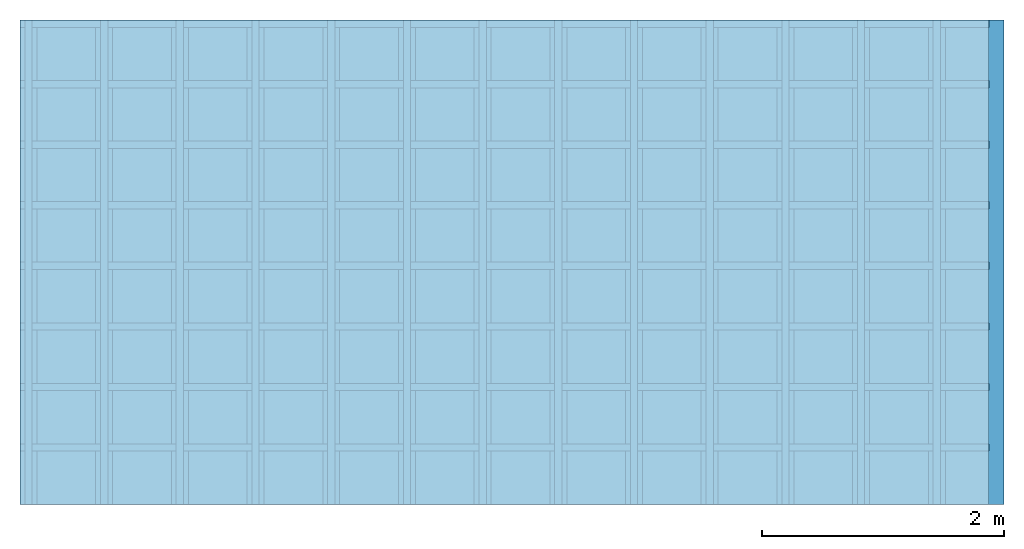
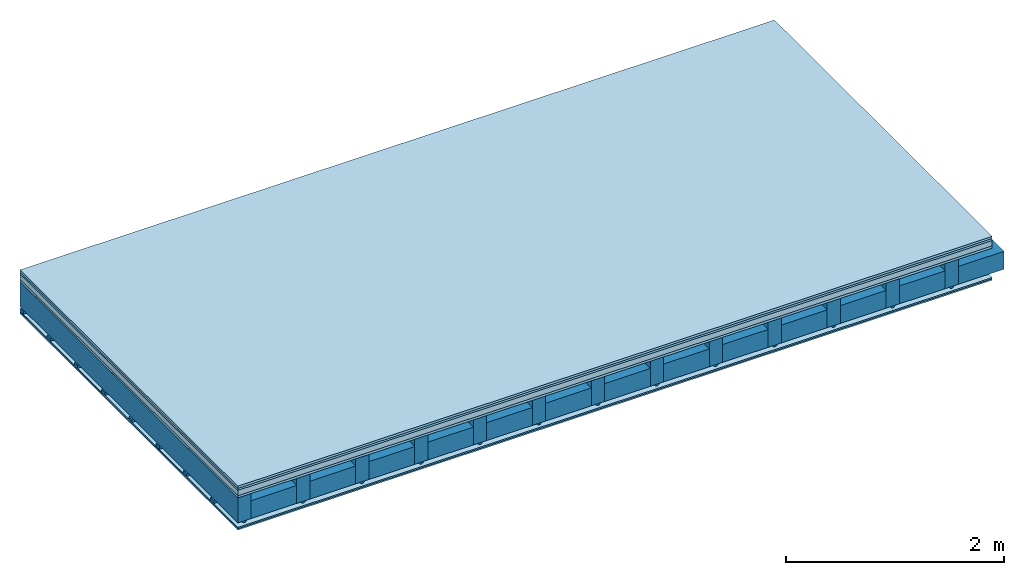
# One storey: 6 plates, 4 members, 1 element without a shape of its own.
"""IFC4 building model written with IfcOpenShell, lengths in metres."""

from ifc_helpers import new_model, si_unit, derived_unit, direction, frame, frame_2d, origin, origin_with_axes, place, context, project, spatial, polyline, rectangle, outline, extrude, material, layer, layer_set, type_object, element, aggregate, save


model = new_model("IFC4")

# Units and contexts
plan_context = context("Plan", 3, precision=1e-05, world=origin(), true_north=direction((0.0, 1.0)))
model_context = context("Model", 3, precision=1e-05, world=origin(), true_north=direction((0.0, 1.0)))
ifc_project = project(units=[si_unit("LENGTHUNIT", "METRE"), derived_unit("SOUNDPRESSUREUNIT", [(si_unit("PRESSUREUNIT", "PASCAL", prefix="MICRO"), 0)]), si_unit("ENERGYUNIT", "JOULE", prefix="MEGA"), si_unit("MASSUNIT", "GRAM", prefix="KILO"), derived_unit("THERMALTRANSMITTANCEUNIT", [(si_unit("POWERUNIT", "WATT"), 1), (si_unit("AREAUNIT", "SQUARE_METRE"), -1), (si_unit("THERMODYNAMICTEMPERATUREUNIT", "KELVIN"), -1)]), derived_unit("AREADENSITYUNIT", [(si_unit("MASSUNIT", "GRAM", prefix="KILO"), 1), (si_unit("AREAUNIT", "SQUARE_METRE"), -1)]), derived_unit("USERDEFINED", [(si_unit("ENERGYUNIT", "JOULE", prefix="MEGA"), 1), (si_unit("AREAUNIT", "SQUARE_METRE"), -1)])], contexts=[plan_context, model_context])

# Site, building, storey
site = spatial("IfcSite", under=ifc_project)
building_placement = place(None, origin())
building = spatial("IfcBuilding", under=site, at=building_placement)
storey_placement = place(building_placement, origin())
storey = spatial("IfcBuildingStorey", under=building, at=storey_placement)

# Slab, members, plates
ifc_material_1 = material(Name="Floor heating system Therm38 longitudinal", Category="03.007")
ifc_layer_1 = layer(ifc_material_1, 0.025, Name="On-material")
ifc_material_2 = material(Category="10.009")
ifc_layer_2 = layer(ifc_material_2, 0.022, Name="Impact sound insulation")
ifc_material_3 = material(Name="Cement panels, glued on sub-floor", Category="02.007")
ifc_layer_3 = layer(ifc_material_3, 0.06, Name="on Supporting structure")
ifc_material_4 = material(Category="07.001")
ifc_layer_4 = layer(ifc_material_4, 0.025, Name="Sub-floor")
ifc_material_5 = material(Name="of the art")
ifc_layer_5 = layer(ifc_material_5, 0.0, Name="Bond")
ifc_layer_6 = layer(None, 0.28, Name="Supporting structure")
ifc_material_6 = material(Name="no composite action")
ifc_layer_7 = layer(ifc_material_6, 0.0, Name="Bond")
ifc_layer_8 = layer(None, 0.02, Name="Coupling")
ifc_layer_9 = layer(None, 0.03, Name="Battens / profiles")
ifc_material_7 = material(Category="03.007")
ifc_layer_10 = layer(ifc_material_7, 0.015, Name="Ceiling covering 1st layer")
ifc_layer_11 = layer(ifc_material_7, 0.015, Name="Ceiling covering layer 2")
ifc_material_8 = material(Name="Glued joints")
ifc_layer_12 = layer(ifc_material_8, 0.0, Name="Surface / treatment")
ifc_layer_set = layer_set([ifc_layer_1, ifc_layer_2, ifc_layer_3, ifc_layer_4, ifc_layer_5, ifc_layer_6, ifc_layer_7, ifc_layer_8, ifc_layer_9, ifc_layer_10, ifc_layer_11, ifc_layer_12])
slab_type = type_object("IfcSlabType", Name="A0250", PredefinedType="NOTDEFINED", material=ifc_layer_set)
slab_placement = place(None, frame((0.0, 0.0, 0.0), z_axis=(0.0, 0.0, -1.0), x_axis=(1.0, 0.0, 0.0)))
slab = element("IfcSlab", 1, at=slab_placement, inside=storey, type_object=slab_type, material=ifc_layer_set, Name="Slab #1")
ifc_material_9 = material()
member_1_placement = place(slab_placement, origin())
member_1 = element("IfcMember", 2, at=member_1_placement, material=ifc_material_9, Name="Supporting structure", context=plan_context, shape_type="SweptSolid", body=[
    extrude(rectangle(XDim=0.14, YDim=0.28, at=frame_2d((0.07, 0.14), x_axis=(1.0, 0.0))), frame((0.0, 4.0, 0.132), z_axis=(0.0, -1.0, 0.0), x_axis=(1.0, 0.0, 0.0)), (0.0, 0.0, 1.0), 4.0),
    extrude(rectangle(XDim=0.14, YDim=0.28, at=frame_2d((0.07, 0.14), x_axis=(1.0, 0.0))), frame((0.625, 4.0, 0.132), z_axis=(0.0, -1.0, 0.0), x_axis=(1.0, 0.0, 0.0)), (0.0, 0.0, 1.0), 4.0),
    extrude(rectangle(XDim=0.14, YDim=0.28, at=frame_2d((0.07, 0.14), x_axis=(1.0, 0.0))), frame((1.25, 4.0, 0.132), z_axis=(0.0, -1.0, 0.0), x_axis=(1.0, 0.0, 0.0)), (0.0, 0.0, 1.0), 4.0),
    extrude(rectangle(XDim=0.14, YDim=0.28, at=frame_2d((0.07, 0.14), x_axis=(1.0, 0.0))), frame((1.875, 4.0, 0.132), z_axis=(0.0, -1.0, 0.0), x_axis=(1.0, 0.0, 0.0)), (0.0, 0.0, 1.0), 4.0),
    extrude(rectangle(XDim=0.14, YDim=0.28, at=frame_2d((0.07, 0.14), x_axis=(1.0, 0.0))), frame((2.5, 4.0, 0.132), z_axis=(0.0, -1.0, 0.0), x_axis=(1.0, 0.0, 0.0)), (0.0, 0.0, 1.0), 4.0),
    extrude(rectangle(XDim=0.14, YDim=0.28, at=frame_2d((0.07, 0.14), x_axis=(1.0, 0.0))), frame((3.125, 4.0, 0.132), z_axis=(0.0, -1.0, 0.0), x_axis=(1.0, 0.0, 0.0)), (0.0, 0.0, 1.0), 4.0),
    extrude(rectangle(XDim=0.14, YDim=0.28, at=frame_2d((0.07, 0.14), x_axis=(1.0, 0.0))), frame((3.75, 4.0, 0.132), z_axis=(0.0, -1.0, 0.0), x_axis=(1.0, 0.0, 0.0)), (0.0, 0.0, 1.0), 4.0),
    extrude(rectangle(XDim=0.14, YDim=0.28, at=frame_2d((0.07, 0.14), x_axis=(1.0, 0.0))), frame((4.375, 4.0, 0.132), z_axis=(0.0, -1.0, 0.0), x_axis=(1.0, 0.0, 0.0)), (0.0, 0.0, 1.0), 4.0),
    extrude(rectangle(XDim=0.14, YDim=0.28, at=frame_2d((0.07, 0.14), x_axis=(1.0, 0.0))), frame((5.0, 4.0, 0.132), z_axis=(0.0, -1.0, 0.0), x_axis=(1.0, 0.0, 0.0)), (0.0, 0.0, 1.0), 4.0),
    extrude(rectangle(XDim=0.14, YDim=0.28, at=frame_2d((0.07, 0.14), x_axis=(1.0, 0.0))), frame((5.625, 4.0, 0.132), z_axis=(0.0, -1.0, 0.0), x_axis=(1.0, 0.0, 0.0)), (0.0, 0.0, 1.0), 4.0),
    extrude(rectangle(XDim=0.14, YDim=0.28, at=frame_2d((0.07, 0.14), x_axis=(1.0, 0.0))), frame((6.25, 4.0, 0.132), z_axis=(0.0, -1.0, 0.0), x_axis=(1.0, 0.0, 0.0)), (0.0, 0.0, 1.0), 4.0),
    extrude(rectangle(XDim=0.14, YDim=0.28, at=frame_2d((0.07, 0.14), x_axis=(1.0, 0.0))), frame((6.875, 4.0, 0.132), z_axis=(0.0, -1.0, 0.0), x_axis=(1.0, 0.0, 0.0)), (0.0, 0.0, 1.0), 4.0),
    extrude(rectangle(XDim=0.14, YDim=0.28, at=frame_2d((0.07, 0.14), x_axis=(1.0, 0.0))), frame((7.5, 4.0, 0.132), z_axis=(0.0, -1.0, 0.0), x_axis=(1.0, 0.0, 0.0)), (0.0, 0.0, 1.0), 4.0),
])
ifc_material_10 = material()
member_2_placement = place(slab_placement, origin())
member_2 = element("IfcMember", 3, at=member_2_placement, material=ifc_material_10, Name="Cavity", context=plan_context, shape_type="SweptSolid", body=[
    extrude(rectangle(XDim=0.485, YDim=0.2, at=frame_2d((0.2425, 0.1), x_axis=(1.0, 0.0))), frame((0.14, 4.0, 0.212), z_axis=(0.0, -1.0, 0.0), x_axis=(1.0, 0.0, 0.0)), (0.0, 0.0, 1.0), 4.0),
    extrude(rectangle(XDim=0.485, YDim=0.2, at=frame_2d((0.2425, 0.1), x_axis=(1.0, 0.0))), frame((0.765, 4.0, 0.212), z_axis=(0.0, -1.0, 0.0), x_axis=(1.0, 0.0, 0.0)), (0.0, 0.0, 1.0), 4.0),
    extrude(rectangle(XDim=0.485, YDim=0.2, at=frame_2d((0.2425, 0.1), x_axis=(1.0, 0.0))), frame((1.39, 4.0, 0.212), z_axis=(0.0, -1.0, 0.0), x_axis=(1.0, 0.0, 0.0)), (0.0, 0.0, 1.0), 4.0),
    extrude(rectangle(XDim=0.485, YDim=0.2, at=frame_2d((0.2425, 0.1), x_axis=(1.0, 0.0))), frame((2.015, 4.0, 0.212), z_axis=(0.0, -1.0, 0.0), x_axis=(1.0, 0.0, 0.0)), (0.0, 0.0, 1.0), 4.0),
    extrude(rectangle(XDim=0.485, YDim=0.2, at=frame_2d((0.2425, 0.1), x_axis=(1.0, 0.0))), frame((2.64, 4.0, 0.212), z_axis=(0.0, -1.0, 0.0), x_axis=(1.0, 0.0, 0.0)), (0.0, 0.0, 1.0), 4.0),
    extrude(rectangle(XDim=0.485, YDim=0.2, at=frame_2d((0.2425, 0.1), x_axis=(1.0, 0.0))), frame((3.265, 4.0, 0.212), z_axis=(0.0, -1.0, 0.0), x_axis=(1.0, 0.0, 0.0)), (0.0, 0.0, 1.0), 4.0),
    extrude(rectangle(XDim=0.485, YDim=0.2, at=frame_2d((0.2425, 0.1), x_axis=(1.0, 0.0))), frame((3.89, 4.0, 0.212), z_axis=(0.0, -1.0, 0.0), x_axis=(1.0, 0.0, 0.0)), (0.0, 0.0, 1.0), 4.0),
    extrude(rectangle(XDim=0.485, YDim=0.2, at=frame_2d((0.2425, 0.1), x_axis=(1.0, 0.0))), frame((4.515, 4.0, 0.212), z_axis=(0.0, -1.0, 0.0), x_axis=(1.0, 0.0, 0.0)), (0.0, 0.0, 1.0), 4.0),
    extrude(rectangle(XDim=0.485, YDim=0.2, at=frame_2d((0.2425, 0.1), x_axis=(1.0, 0.0))), frame((5.14, 4.0, 0.212), z_axis=(0.0, -1.0, 0.0), x_axis=(1.0, 0.0, 0.0)), (0.0, 0.0, 1.0), 4.0),
    extrude(rectangle(XDim=0.485, YDim=0.2, at=frame_2d((0.2425, 0.1), x_axis=(1.0, 0.0))), frame((5.765, 4.0, 0.212), z_axis=(0.0, -1.0, 0.0), x_axis=(1.0, 0.0, 0.0)), (0.0, 0.0, 1.0), 4.0),
    extrude(rectangle(XDim=0.485, YDim=0.2, at=frame_2d((0.2425, 0.1), x_axis=(1.0, 0.0))), frame((6.39, 4.0, 0.212), z_axis=(0.0, -1.0, 0.0), x_axis=(1.0, 0.0, 0.0)), (0.0, 0.0, 1.0), 4.0),
    extrude(rectangle(XDim=0.485, YDim=0.2, at=frame_2d((0.2425, 0.1), x_axis=(1.0, 0.0))), frame((7.015, 4.0, 0.212), z_axis=(0.0, -1.0, 0.0), x_axis=(1.0, 0.0, 0.0)), (0.0, 0.0, 1.0), 4.0),
    extrude(rectangle(XDim=0.485, YDim=0.2, at=frame_2d((0.2425, 0.1), x_axis=(1.0, 0.0))), frame((7.64, 4.0, 0.212), z_axis=(0.0, -1.0, 0.0), x_axis=(1.0, 0.0, 0.0)), (0.0, 0.0, 1.0), 4.0),
])
ifc_material_11 = material()
member_3_placement = place(slab_placement, origin())
member_3 = element("IfcMember", 4, at=member_3_placement, material=ifc_material_11, Name="Coupling", context=plan_context, shape_type="SweptSolid", body=[
    extrude(outline(polyline([(0.0, 0.0), (0.06, 0.0), (0.04, 0.02), (0.02, 0.02), (0.0, 0.0)])), frame((0.04, 4.0, 0.412), z_axis=(0.0, -1.0, 0.0), x_axis=(1.0, 0.0, 0.0)), (0.0, 0.0, 1.0), 4.0),
    extrude(outline(polyline([(0.0, 0.0), (0.06, 0.0), (0.04, 0.02), (0.02, 0.02), (0.0, 0.0)])), frame((0.665, 4.0, 0.412), z_axis=(0.0, -1.0, 0.0), x_axis=(1.0, 0.0, 0.0)), (0.0, 0.0, 1.0), 4.0),
    extrude(outline(polyline([(0.0, 0.0), (0.06, 0.0), (0.04, 0.02), (0.02, 0.02), (0.0, 0.0)])), frame((1.29, 4.0, 0.412), z_axis=(0.0, -1.0, 0.0), x_axis=(1.0, 0.0, 0.0)), (0.0, 0.0, 1.0), 4.0),
    extrude(outline(polyline([(0.0, 0.0), (0.06, 0.0), (0.04, 0.02), (0.02, 0.02), (0.0, 0.0)])), frame((1.915, 4.0, 0.412), z_axis=(0.0, -1.0, 0.0), x_axis=(1.0, 0.0, 0.0)), (0.0, 0.0, 1.0), 4.0),
    extrude(outline(polyline([(0.0, 0.0), (0.06, 0.0), (0.04, 0.02), (0.02, 0.02), (0.0, 0.0)])), frame((2.54, 4.0, 0.412), z_axis=(0.0, -1.0, 0.0), x_axis=(1.0, 0.0, 0.0)), (0.0, 0.0, 1.0), 4.0),
    extrude(outline(polyline([(0.0, 0.0), (0.06, 0.0), (0.04, 0.02), (0.02, 0.02), (0.0, 0.0)])), frame((3.165, 4.0, 0.412), z_axis=(0.0, -1.0, 0.0), x_axis=(1.0, 0.0, 0.0)), (0.0, 0.0, 1.0), 4.0),
    extrude(outline(polyline([(0.0, 0.0), (0.06, 0.0), (0.04, 0.02), (0.02, 0.02), (0.0, 0.0)])), frame((3.79, 4.0, 0.412), z_axis=(0.0, -1.0, 0.0), x_axis=(1.0, 0.0, 0.0)), (0.0, 0.0, 1.0), 4.0),
    extrude(outline(polyline([(0.0, 0.0), (0.06, 0.0), (0.04, 0.02), (0.02, 0.02), (0.0, 0.0)])), frame((4.415, 4.0, 0.412), z_axis=(0.0, -1.0, 0.0), x_axis=(1.0, 0.0, 0.0)), (0.0, 0.0, 1.0), 4.0),
    extrude(outline(polyline([(0.0, 0.0), (0.06, 0.0), (0.04, 0.02), (0.02, 0.02), (0.0, 0.0)])), frame((5.04, 4.0, 0.412), z_axis=(0.0, -1.0, 0.0), x_axis=(1.0, 0.0, 0.0)), (0.0, 0.0, 1.0), 4.0),
    extrude(outline(polyline([(0.0, 0.0), (0.06, 0.0), (0.04, 0.02), (0.02, 0.02), (0.0, 0.0)])), frame((5.665, 4.0, 0.412), z_axis=(0.0, -1.0, 0.0), x_axis=(1.0, 0.0, 0.0)), (0.0, 0.0, 1.0), 4.0),
    extrude(outline(polyline([(0.0, 0.0), (0.06, 0.0), (0.04, 0.02), (0.02, 0.02), (0.0, 0.0)])), frame((6.29, 4.0, 0.412), z_axis=(0.0, -1.0, 0.0), x_axis=(1.0, 0.0, 0.0)), (0.0, 0.0, 1.0), 4.0),
    extrude(outline(polyline([(0.0, 0.0), (0.06, 0.0), (0.04, 0.02), (0.02, 0.02), (0.0, 0.0)])), frame((6.915, 4.0, 0.412), z_axis=(0.0, -1.0, 0.0), x_axis=(1.0, 0.0, 0.0)), (0.0, 0.0, 1.0), 4.0),
    extrude(outline(polyline([(0.0, 0.0), (0.06, 0.0), (0.04, 0.02), (0.02, 0.02), (0.0, 0.0)])), frame((7.54, 4.0, 0.412), z_axis=(0.0, -1.0, 0.0), x_axis=(1.0, 0.0, 0.0)), (0.0, 0.0, 1.0), 4.0),
])
ifc_material_12 = material()
member_4_placement = place(slab_placement, origin())
member_4 = element("IfcMember", 5, at=member_4_placement, material=ifc_material_12, Name="Battens / profiles", context=plan_context, shape_type="SweptSolid", body=[
    extrude(rectangle(XDim=0.06, YDim=0.03, at=frame_2d((0.03, 0.015), x_axis=(1.0, 0.0))), frame((0.0, 0.0, 0.432), z_axis=(1.0, 0.0, 0.0), x_axis=(0.0, 1.0, 0.0)), (0.0, 0.0, 1.0), 8.0),
    extrude(rectangle(XDim=0.06, YDim=0.03, at=frame_2d((0.03, 0.015), x_axis=(1.0, 0.0))), frame((0.0, 0.5, 0.432), z_axis=(1.0, 0.0, 0.0), x_axis=(0.0, 1.0, 0.0)), (0.0, 0.0, 1.0), 8.0),
    extrude(rectangle(XDim=0.06, YDim=0.03, at=frame_2d((0.03, 0.015), x_axis=(1.0, 0.0))), frame((0.0, 1.0, 0.432), z_axis=(1.0, 0.0, 0.0), x_axis=(0.0, 1.0, 0.0)), (0.0, 0.0, 1.0), 8.0),
    extrude(rectangle(XDim=0.06, YDim=0.03, at=frame_2d((0.03, 0.015), x_axis=(1.0, 0.0))), frame((0.0, 1.5, 0.432), z_axis=(1.0, 0.0, 0.0), x_axis=(0.0, 1.0, 0.0)), (0.0, 0.0, 1.0), 8.0),
    extrude(rectangle(XDim=0.06, YDim=0.03, at=frame_2d((0.03, 0.015), x_axis=(1.0, 0.0))), frame((0.0, 2.0, 0.432), z_axis=(1.0, 0.0, 0.0), x_axis=(0.0, 1.0, 0.0)), (0.0, 0.0, 1.0), 8.0),
    extrude(rectangle(XDim=0.06, YDim=0.03, at=frame_2d((0.03, 0.015), x_axis=(1.0, 0.0))), frame((0.0, 2.5, 0.432), z_axis=(1.0, 0.0, 0.0), x_axis=(0.0, 1.0, 0.0)), (0.0, 0.0, 1.0), 8.0),
    extrude(rectangle(XDim=0.06, YDim=0.03, at=frame_2d((0.03, 0.015), x_axis=(1.0, 0.0))), frame((0.0, 3.0, 0.432), z_axis=(1.0, 0.0, 0.0), x_axis=(0.0, 1.0, 0.0)), (0.0, 0.0, 1.0), 8.0),
    extrude(rectangle(XDim=0.06, YDim=0.03, at=frame_2d((0.03, 0.015), x_axis=(1.0, 0.0))), frame((0.0, 3.5, 0.432), z_axis=(1.0, 0.0, 0.0), x_axis=(0.0, 1.0, 0.0)), (0.0, 0.0, 1.0), 8.0),
])
plate_1_placement = place(slab_placement, origin())
plate_1 = element("IfcPlate", 6, at=plate_1_placement, material=ifc_material_1, Name="On-material", context=plan_context, shape_type="SweptSolid", body=[
    extrude(rectangle(XDim=8.0, YDim=4.0, at=frame_2d((4.0, 2.0), x_axis=(1.0, 0.0))), origin_with_axes(), (0.0, 0.0, 1.0), 0.025),
])
plate_2_placement = place(slab_placement, origin())
plate_2 = element("IfcPlate", 7, at=plate_2_placement, material=ifc_material_2, Name="Impact sound insulation", context=plan_context, shape_type="SweptSolid", body=[
    extrude(rectangle(XDim=8.0, YDim=4.0, at=frame_2d((4.0, 2.0), x_axis=(1.0, 0.0))), frame((0.0, 0.0, 0.025), z_axis=(0.0, 0.0, 1.0), x_axis=(1.0, 0.0, 0.0)), (0.0, 0.0, 1.0), 0.022),
])
plate_3_placement = place(slab_placement, origin())
plate_3 = element("IfcPlate", 8, at=plate_3_placement, material=ifc_material_3, Name="on Supporting structure", context=plan_context, shape_type="SweptSolid", body=[
    extrude(rectangle(XDim=8.0, YDim=4.0, at=frame_2d((4.0, 2.0), x_axis=(1.0, 0.0))), frame((0.0, 0.0, 0.047), z_axis=(0.0, 0.0, 1.0), x_axis=(1.0, 0.0, 0.0)), (0.0, 0.0, 1.0), 0.06),
])
plate_4_placement = place(slab_placement, origin())
plate_4 = element("IfcPlate", 9, at=plate_4_placement, material=ifc_material_4, Name="Sub-floor", context=plan_context, shape_type="SweptSolid", body=[
    extrude(rectangle(XDim=8.0, YDim=4.0, at=frame_2d((4.0, 2.0), x_axis=(1.0, 0.0))), frame((0.0, 0.0, 0.107), z_axis=(0.0, 0.0, 1.0), x_axis=(1.0, 0.0, 0.0)), (0.0, 0.0, 1.0), 0.025),
])
plate_5_placement = place(slab_placement, origin())
plate_5 = element("IfcPlate", 10, at=plate_5_placement, material=ifc_material_7, Name="Ceiling covering 1st layer", context=plan_context, shape_type="SweptSolid", body=[
    extrude(rectangle(XDim=8.0, YDim=4.0, at=frame_2d((4.0, 2.0), x_axis=(1.0, 0.0))), frame((0.0, 0.0, 0.462), z_axis=(0.0, 0.0, 1.0), x_axis=(1.0, 0.0, 0.0)), (0.0, 0.0, 1.0), 0.015),
])
plate_6_placement = place(slab_placement, origin())
plate_6 = element("IfcPlate", 11, at=plate_6_placement, material=ifc_material_7, Name="Ceiling covering layer 2", context=plan_context, shape_type="SweptSolid", body=[
    extrude(rectangle(XDim=8.0, YDim=4.0, at=frame_2d((4.0, 2.0), x_axis=(1.0, 0.0))), frame((0.0, 0.0, 0.477), z_axis=(0.0, 0.0, 1.0), x_axis=(1.0, 0.0, 0.0)), (0.0, 0.0, 1.0), 0.015),
])
aggregate(slab, [plate_1, plate_2, plate_3, plate_4, member_1, member_2, member_3, member_4, plate_5, plate_6])

save(model, "model.ifc")
